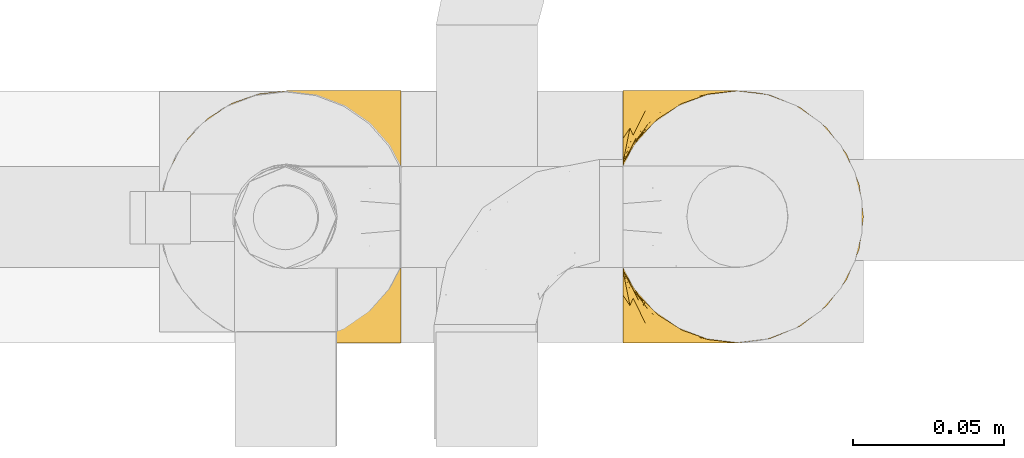
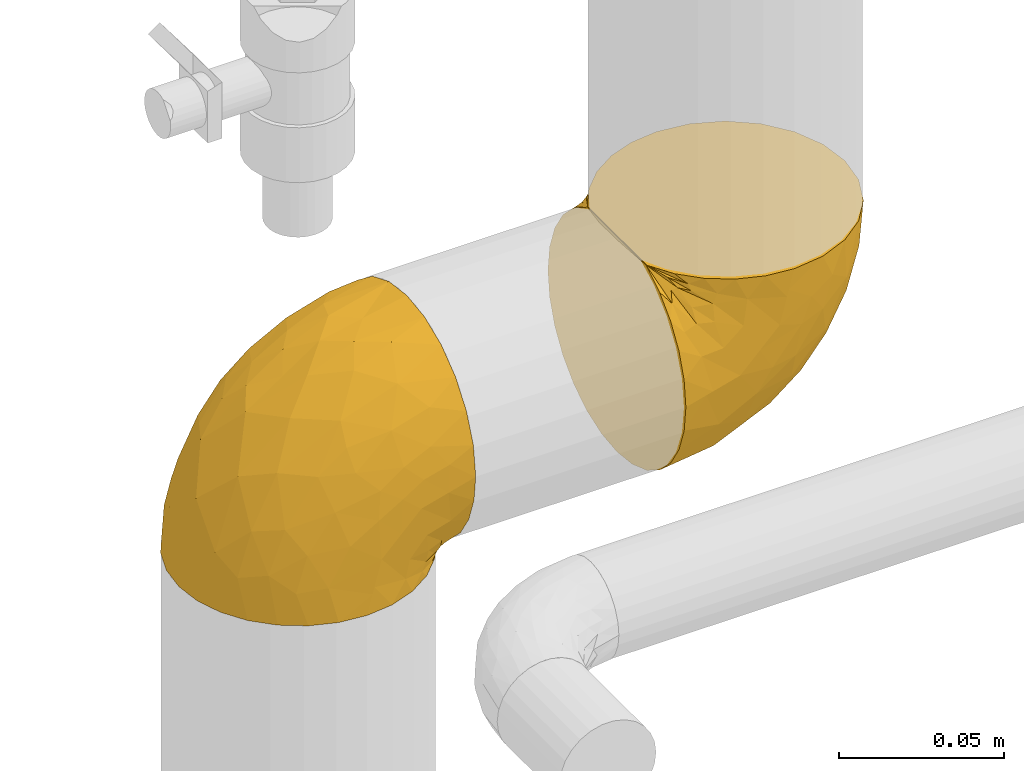
# One storey, part 358 of 827: 2 coverings.
"""IFC2X3 building model written with IfcOpenShell, lengths in millimetres."""

from ifc_helpers import new_model, entity, si_unit, converted_unit, derived_unit, direction, frame, origin, place, context, subcontext, project, spatial, faceted_brep, element, save


model = new_model("IFC2X3")

# Units and contexts
model_context = context("Model", 3, precision=0.01, world=origin(), true_north=direction((6.12303176911189e-17, 1.0)))
body_context = subcontext(model_context, "Body", "Model", "MODEL_VIEW")
ifc_project = project(units=[si_unit("LENGTHUNIT", "METRE", prefix="MILLI"), si_unit("AREAUNIT", "SQUARE_METRE"), si_unit("VOLUMEUNIT", "CUBIC_METRE"), converted_unit("PLANEANGLEUNIT", "DEGREE", entity("IfcRatioMeasure", 0.0174532925199433), si_unit("PLANEANGLEUNIT", "RADIAN"), dimensions=[0, 0, 0, 0, 0, 0, 0]), si_unit("MASSUNIT", "GRAM", prefix="KILO"), derived_unit("MASSDENSITYUNIT", [(si_unit("MASSUNIT", "GRAM", prefix="KILO"), 1), (si_unit("LENGTHUNIT", "METRE"), -3)]), derived_unit("MOMENTOFINERTIAUNIT", [(si_unit("LENGTHUNIT", "METRE"), 4)]), si_unit("TIMEUNIT", "SECOND"), si_unit("FREQUENCYUNIT", "HERTZ"), si_unit("THERMODYNAMICTEMPERATUREUNIT", "DEGREE_CELSIUS"), derived_unit("THERMALTRANSMITTANCEUNIT", [(si_unit("MASSUNIT", "GRAM", prefix="KILO"), 1), (si_unit("THERMODYNAMICTEMPERATUREUNIT", "KELVIN"), -1), (si_unit("TIMEUNIT", "SECOND"), -3)]), derived_unit("VOLUMETRICFLOWRATEUNIT", [(si_unit("LENGTHUNIT", "METRE"), 3), (si_unit("TIMEUNIT", "SECOND"), -1)]), derived_unit("MASSFLOWRATEUNIT", [(si_unit("MASSUNIT", "GRAM", prefix="KILO"), 1), (si_unit("TIMEUNIT", "SECOND"), -1)]), derived_unit("ROTATIONALFREQUENCYUNIT", [(si_unit("TIMEUNIT", "SECOND"), -1)]), si_unit("ELECTRICCURRENTUNIT", "AMPERE"), si_unit("ELECTRICVOLTAGEUNIT", "VOLT"), si_unit("POWERUNIT", "WATT"), si_unit("FORCEUNIT", "NEWTON", prefix="KILO"), si_unit("ILLUMINANCEUNIT", "LUX"), si_unit("LUMINOUSFLUXUNIT", "LUMEN"), si_unit("LUMINOUSINTENSITYUNIT", "CANDELA"), derived_unit("USERDEFINED", [(si_unit("MASSUNIT", "GRAM", prefix="KILO"), -1), (si_unit("LENGTHUNIT", "METRE"), -2), (si_unit("TIMEUNIT", "SECOND"), 3), (si_unit("LUMINOUSFLUXUNIT", "LUMEN"), 1)]), derived_unit("LINEARVELOCITYUNIT", [(si_unit("LENGTHUNIT", "METRE"), 1), (si_unit("TIMEUNIT", "SECOND"), -1)]), si_unit("PRESSUREUNIT", "PASCAL"), derived_unit("USERDEFINED", [(si_unit("LENGTHUNIT", "METRE"), -2), (si_unit("MASSUNIT", "GRAM", prefix="KILO"), 1), (si_unit("TIMEUNIT", "SECOND"), -2)]), derived_unit("LINEARFORCEUNIT", [(si_unit("MASSUNIT", "GRAM", prefix="KILO"), 1), (si_unit("LENGTHUNIT", "METRE"), 1), (si_unit("TIMEUNIT", "SECOND"), -2), (si_unit("LENGTHUNIT", "METRE"), -1)]), derived_unit("PLANARFORCEUNIT", [(si_unit("MASSUNIT", "GRAM", prefix="KILO"), 1), (si_unit("LENGTHUNIT", "METRE"), 1), (si_unit("TIMEUNIT", "SECOND"), -2), (si_unit("LENGTHUNIT", "METRE"), -2)])], contexts=[model_context])

# Site, building, storey
site_placement = place(None, origin())
site = spatial("IfcSite", under=ifc_project, at=site_placement, CompositionType="ELEMENT")
building_placement = place(site_placement, origin())
building = spatial("IfcBuilding", under=site, at=building_placement, CompositionType="ELEMENT")
storey_placement = place(building_placement, frame((0.0, 0.0, 28200.0)))
storey = spatial("IfcBuildingStorey", under=building, at=storey_placement, Name="08", CompositionType="ELEMENT", Elevation=28200.0)

# Coverings
covering_1_placement = place(storey_placement, frame((43263.49, 18027.79, 1216.43)))
element("IfcCovering", 1, at=covering_1_placement, inside=storey, Name=":ADSK_", ObjectType=":ADSK_", PredefinedType="INSULATION", context=body_context, shape_type="Brep", body=[
    faceted_brep([(1.6, 81.15, 25.28), (1.6, 76.16, 17.35), (1.6, 69.53, 10.72), (1.6, 61.6, 5.74), (1.6, 52.75, 2.64), (1.6, 43.45, 1.6), (1.6, 34.13, 2.65), (1.6, 25.28, 5.74), (1.6, 17.35, 10.73), (1.6, 10.72, 17.36), (1.6, 5.74, 25.29), (1.6, 2.64, 34.14), (1.6, 1.6, 43.45), (1.6, 2.66, 52.82), (1.6, 5.79, 61.71), (1.6, 10.83, 69.67), (1.6, 17.53, 76.31), (1.6, 25.53, 81.27), (1.6, 26.45, 81.27), (1.6, 27.37, 81.27), (1.6, 28.17, 81.27), (1.6, 29.49, 81.27), (1.6, 30.81, 81.27), (1.6, 32.13, 81.27), (1.6, 33.45, 81.27), (1.6, 34.78, 81.27), (1.6, 36.1, 81.27), (1.6, 37.42, 81.27), (1.6, 38.74, 81.27), (1.6, 40.06, 81.27), (1.6, 41.38, 81.27), (1.6, 42.7, 81.27), (1.6, 44.02, 81.27), (1.6, 45.34, 81.27), (1.6, 46.66, 81.27), (1.6, 47.58, 81.27), (1.6, 48.5, 81.27), (1.6, 49.41, 81.27), (1.6, 50.33, 81.27), (1.6, 51.25, 81.27), (1.6, 52.17, 81.27), (1.6, 53.09, 81.27), (1.6, 54.01, 81.27), (1.6, 54.93, 81.27), (1.6, 55.85, 81.27), (1.6, 56.76, 81.27), (1.6, 57.68, 81.27), (1.6, 58.6, 81.27), (1.6, 59.52, 81.27), (1.6, 60.44, 81.27), (1.6, 61.36, 81.27), (1.6, 69.37, 76.3), (1.6, 76.07, 69.66), (1.6, 81.11, 61.69), (1.6, 84.24, 52.8), (1.6, 85.3, 43.45), (1.6, 84.24, 34.13), (6.74, 17.52, 81.45), (13.37, 10.83, 81.45), (21.34, 5.79, 81.45), (30.23, 2.66, 81.45), (39.6, 1.6, 81.45), (50.43, 3.02, 81.45), (60.52, 7.2, 81.45), (69.19, 13.85, 81.45), (75.84, 22.52, 81.45), (80.02, 32.61, 81.45), (81.45, 43.45, 81.45), (80.02, 54.28, 81.45), (75.84, 64.37, 81.45), (69.19, 73.04, 81.45), (60.52, 79.69, 81.45), (50.43, 83.87, 81.45), (39.6, 85.3, 81.45), (30.23, 84.23, 81.45), (21.34, 81.1, 81.45), (13.37, 76.06, 81.45), (6.74, 69.37, 81.45), (1.77, 61.36, 81.45), (1.77, 60.44, 81.45), (1.77, 59.12, 81.45), (1.77, 58.0, 81.45), (1.77, 56.88, 81.45), (1.77, 55.76, 81.45), (1.77, 54.64, 81.45), (1.77, 53.52, 81.45), (1.77, 52.4, 81.45), (1.77, 51.28, 81.45), (1.77, 50.16, 81.45), (1.77, 49.04, 81.45), (1.77, 47.92, 81.45), (1.77, 46.8, 81.45), (1.77, 45.68, 81.45), (1.77, 44.56, 81.45), (1.77, 43.45, 81.45), (1.77, 42.12, 81.45), (1.77, 40.8, 81.45), (1.77, 39.48, 81.45), (1.77, 38.16, 81.45), (1.77, 36.84, 81.45), (1.77, 35.52, 81.45), (1.77, 34.2, 81.45), (1.77, 32.88, 81.45), (1.77, 31.96, 81.45), (1.77, 31.05, 81.45), (1.77, 30.13, 81.45), (1.77, 29.21, 81.45), (1.77, 28.29, 81.45), (1.77, 27.37, 81.45), (1.77, 26.45, 81.45), (1.77, 25.53, 81.45), (1.73, 54.08, 81.33), (1.72, 55.16, 81.32), (1.73, 36.18, 81.33), (1.72, 35.13, 81.32), (1.73, 44.01, 81.33), (1.73, 45.08, 81.32), (1.72, 61.36, 81.32), (1.72, 59.98, 81.32), (1.72, 46.18, 81.32), (1.72, 26.74, 81.32), (1.72, 47.36, 81.32), (1.73, 29.67, 81.32), (1.74, 28.72, 81.34), (1.72, 39.77, 81.32), (1.71, 52.96, 81.31), (1.73, 51.84, 81.33), (1.71, 40.8, 81.31), (1.72, 41.87, 81.32), (1.73, 42.94, 81.33), (1.72, 27.77, 81.32), (1.73, 48.4, 81.33), (1.72, 37.21, 81.32), (1.73, 33.54, 81.33), (1.72, 32.49, 81.32), (1.72, 30.69, 81.32), (1.72, 50.69, 81.32), (1.71, 49.6, 81.31), (1.72, 56.32, 81.32), (1.73, 57.44, 81.33), (1.71, 58.88, 81.31), (1.72, 25.53, 81.32), (1.68, 61.36, 81.3), (1.64, 61.36, 81.29), (1.64, 25.53, 81.29), (1.68, 25.53, 81.3), (1.75, 61.36, 81.4), (1.74, 61.36, 81.36), (1.74, 25.53, 81.36), (1.75, 25.53, 81.4), (1.7, 31.59, 81.3), (1.73, 38.71, 81.33), (24.54, 3.97, 74.06), (11.1, 1.6, 45.99), (8.47, 3.97, 58.35), (9.11, 8.09, 67.76), (4.86, 8.09, 66.18), (5.0, 16.43, 76.46), (6.81, 15.73, 77.33), (37.05, 1.6, 71.95), (9.03, 10.79, 72.25), (9.47, 13.99, 78.91), (16.39, 8.08, 76.42), (3.95, 14.0, 73.52), (9.9, 12.83, 76.9), (22.7, 3.18, 65.25), (34.5, 1.6, 62.45), (37.68, 1.6, 74.31), (15.82, 3.28, 59.38), (20.6, 1.6, 48.54), (14.37, 6.28, 67.72), (27.55, 1.6, 55.49), (5.2, 19.06, 79.73), (14.88, 8.08, 73.23), (8.73, 1.6, 45.36), (44.27, 32.11, 15.81), (20.94, 29.62, 6.4), (32.15, 43.45, 7.67), (46.13, 2.45, 68.46), (42.67, 2.5, 59.33), (55.18, 9.73, 48.7), (67.27, 17.97, 53.94), (62.91, 10.24, 65.02), (51.5, 4.78, 60.77), (54.79, 4.78, 72.07), (25.78, 8.01, 26.25), (13.05, 8.01, 22.29), (18.46, 13.85, 16.0), (32.4, 2.42, 46.93), (31.07, 21.17, 14.19), (77.32, 35.73, 58.46), (75.62, 27.43, 61.51), (16.9, 43.45, 4.64), (71.69, 17.97, 68.93), (61.4, 35.71, 29.62), (54.47, 29.47, 24.85), (27.66, 3.41, 38.55), (14.53, 3.94, 31.27), (15.56, 21.17, 9.35), (42.26, 7.92, 37.15), (41.51, 4.25, 47.07), (36.93, 11.75, 26.49), (42.72, 18.31, 23.01), (44.68, 24.94, 19.4), (71.2, 28.78, 48.06), (70.48, 35.82, 42.46), (75.37, 43.45, 50.89), (63.65, 28.38, 35.78), (58.06, 43.45, 24.98), (45.11, 43.45, 16.33), (78.4, 43.45, 66.14), (54.95, 21.21, 30.96), (59.31, 16.48, 41.83), (49.01, 13.85, 33.28), (66.71, 43.45, 37.94), (53.75, 82.11, 67.39), (77.27, 51.41, 58.47), (61.6, 57.45, 32.5), (44.24, 54.78, 15.79), (18.46, 73.03, 15.99), (15.55, 65.7, 9.34), (60.14, 76.65, 56.91), (70.5, 68.92, 63.5), (63.0, 68.01, 44.08), (25.78, 78.88, 26.24), (13.05, 78.88, 22.27), (14.53, 82.94, 31.26), (48.5, 64.44, 23.95), (44.23, 84.49, 63.79), (34.5, 85.3, 62.45), (37.05, 85.3, 71.95), (8.73, 85.3, 45.36), (77.68, 57.84, 67.83), (64.08, 76.65, 70.28), (70.25, 51.19, 42.11), (20.93, 57.26, 6.39), (49.9, 78.14, 43.54), (49.6, 82.35, 58.03), (31.06, 65.7, 14.18), (39.62, 84.61, 56.34), (34.42, 84.36, 48.09), (20.6, 85.3, 48.54), (27.55, 85.3, 55.49), (33.36, 73.03, 21.78), (27.68, 83.48, 38.54), (11.1, 85.3, 45.99), (46.67, 84.54, 72.79), (49.0, 73.03, 33.26), (38.94, 79.54, 35.53), (73.05, 59.46, 53.66), (56.63, 73.5, 43.03), (43.85, 82.57, 49.68), (24.54, 82.92, 74.06), (15.82, 83.62, 59.37), (8.47, 82.92, 58.34), (9.12, 78.81, 67.75), (9.47, 72.9, 78.91), (9.91, 74.06, 76.9), (16.85, 78.81, 78.08), (14.88, 78.81, 73.23), (5.2, 67.83, 79.73), (6.81, 71.15, 77.34), (3.96, 72.91, 73.51), (5.0, 70.47, 76.45), (5.86, 78.81, 66.41), (14.38, 80.62, 67.7), (9.04, 76.11, 72.24), (22.7, 83.71, 65.25)], [[[0, 1, 2, 3, 4, 5, 6, 7, 8, 9, 10, 11, 12, 13, 14, 15, 16, 17, 18, 19, 20, 21, 22, 23, 24, 25, 26, 27, 28, 29, 30, 31, 32, 33, 34, 35, 36, 37, 38, 39, 40, 41, 42, 43, 44, 45, 46, 47, 48, 49, 50, 51, 52, 53, 54, 55, 56]], [[57, 58, 59, 60, 61, 62, 63, 64, 65, 66, 67, 68, 69, 70, 71, 72, 73, 74, 75, 76, 77, 78, 79, 80, 81, 82, 83, 84, 85, 86, 87, 88, 89, 90, 91, 92, 93, 94, 95, 96, 97, 98, 99, 100, 101, 102, 103, 104, 105, 106, 107, 108, 109, 110]], [[111, 84, 112]], [[113, 26, 114]], [[114, 101, 100]], [[115, 93, 116]], [[79, 117, 118]], [[33, 116, 119]], [[117, 49, 118]], [[19, 18, 120]], [[119, 121, 34]], [[122, 21, 123]], [[97, 96, 124]], [[86, 125, 126]], [[116, 92, 119]], [[127, 96, 128]], [[32, 129, 115]], [[19, 120, 130]], [[121, 90, 131]], [[94, 115, 129]], [[115, 116, 32]], [[118, 49, 48]], [[113, 99, 132]], [[133, 114, 25]], [[24, 134, 133]], [[135, 22, 122]], [[136, 137, 88]], [[84, 83, 112]], [[138, 82, 139]], [[130, 20, 19]], [[118, 48, 140]], [[81, 140, 139]], [[123, 21, 20]], [[141, 120, 18]], [[139, 82, 81]], [[130, 107, 123]], [[49, 117, 142, 143, 50]], [[18, 17, 144, 145, 141]], [[79, 78, 146, 147, 117]], [[109, 141, 148, 149, 110]], [[102, 133, 134]], [[105, 135, 122]], [[118, 80, 79]], [[80, 118, 140]], [[120, 109, 108]], [[47, 46, 140, 48]], [[81, 80, 140]], [[44, 112, 138]], [[93, 115, 94]], [[46, 139, 140]], [[46, 45, 139]], [[139, 45, 138]], [[138, 112, 83]], [[85, 84, 111]], [[112, 43, 111]], [[83, 82, 138]], [[106, 122, 123]], [[105, 122, 106]], [[21, 122, 22]], [[124, 29, 28]], [[33, 32, 116]], [[128, 129, 31]], [[32, 31, 129]], [[34, 33, 119]], [[116, 93, 92]], [[129, 95, 94]], [[95, 129, 128]], [[41, 40, 125, 42]], [[119, 91, 121]], [[36, 35, 131, 37]], [[137, 131, 89]], [[121, 131, 35]], [[90, 121, 91]], [[119, 92, 91]], [[136, 126, 39]], [[125, 86, 85]], [[42, 125, 111]], [[85, 111, 125]], [[150, 23, 22]], [[130, 108, 107]], [[130, 123, 20]], [[107, 106, 123]], [[137, 37, 131]], [[136, 38, 137]], [[89, 88, 137]], [[131, 90, 89]], [[124, 151, 97]], [[40, 39, 126]], [[87, 126, 136]], [[86, 126, 87]], [[136, 88, 87]], [[40, 126, 125]], [[39, 38, 136]], [[95, 128, 96]], [[30, 128, 31]], [[29, 124, 127]], [[127, 128, 30]], [[151, 124, 28]], [[127, 30, 29]], [[127, 124, 96]], [[151, 98, 97]], [[45, 44, 138]], [[26, 113, 132]], [[113, 100, 99]], [[132, 151, 27]], [[27, 26, 132]], [[26, 25, 114]], [[100, 113, 114]], [[101, 133, 102]], [[133, 101, 114]], [[28, 27, 151]], [[132, 99, 98]], [[23, 134, 24]], [[25, 24, 133]], [[134, 23, 150]], [[135, 104, 150]], [[150, 104, 103]], [[103, 102, 134]], [[130, 120, 108]], [[109, 120, 141]], [[42, 111, 43]], [[112, 44, 43]], [[104, 135, 105]], [[134, 150, 103]], [[135, 150, 22]], [[35, 34, 121]], [[137, 38, 37]], [[98, 151, 132]], [[59, 152, 60]], [[13, 153, 154]], [[155, 156, 154]], [[157, 158, 141]], [[159, 60, 152]], [[160, 157, 155]], [[161, 162, 58]], [[58, 162, 59]], [[144, 16, 163]], [[58, 57, 161]], [[162, 161, 164]], [[157, 163, 155]], [[163, 16, 15]], [[57, 149, 161]], [[152, 165, 166]], [[157, 144, 163]], [[60, 159, 167, 61]], [[156, 14, 154]], [[163, 156, 155]], [[155, 154, 168]], [[168, 154, 169]], [[155, 170, 160]], [[57, 110, 149]], [[144, 17, 16]], [[156, 15, 14]], [[171, 165, 168]], [[158, 164, 172]], [[14, 13, 154]], [[157, 145, 144]], [[173, 164, 158]], [[173, 160, 170]], [[171, 166, 165]], [[168, 165, 170]], [[168, 169, 171]], [[152, 173, 165]], [[170, 155, 168]], [[165, 173, 170]], [[160, 173, 158]], [[172, 149, 148]], [[148, 141, 158]], [[158, 157, 160]], [[152, 166, 159]], [[173, 152, 162]], [[59, 162, 152]], [[13, 12, 174, 153]], [[153, 169, 154]], [[15, 156, 163]], [[157, 141, 145]], [[162, 164, 173]], [[172, 164, 161]], [[149, 172, 161]], [[158, 172, 148]], [[175, 176, 177]], [[178, 166, 179]], [[180, 181, 182]], [[183, 184, 178]], [[185, 186, 187]], [[171, 188, 179]], [[174, 12, 11]], [[189, 176, 175]], [[190, 66, 191]], [[176, 6, 192]], [[193, 65, 64]], [[63, 184, 182]], [[63, 182, 64]], [[65, 193, 191]], [[184, 63, 62]], [[175, 194, 195]], [[196, 169, 197]], [[174, 11, 197]], [[8, 7, 198]], [[187, 9, 8]], [[197, 169, 153, 174]], [[197, 11, 10]], [[186, 197, 10]], [[199, 180, 200]], [[197, 185, 196]], [[201, 189, 202]], [[201, 187, 189]], [[195, 203, 175]], [[191, 204, 190]], [[176, 7, 6]], [[177, 176, 192]], [[189, 198, 176]], [[65, 191, 66]], [[198, 187, 8]], [[205, 206, 190]], [[9, 186, 10]], [[181, 207, 204]], [[208, 175, 177, 209]], [[66, 190, 210]], [[211, 212, 213]], [[190, 204, 205]], [[180, 182, 183]], [[193, 182, 181]], [[62, 61, 167]], [[196, 185, 199]], [[196, 200, 188]], [[6, 5, 192]], [[176, 198, 7]], [[187, 198, 189]], [[187, 186, 9]], [[197, 186, 185]], [[200, 180, 183]], [[180, 213, 212]], [[179, 183, 178]], [[185, 201, 199]], [[210, 190, 206]], [[210, 67, 66]], [[205, 204, 207]], [[194, 205, 207]], [[194, 214, 205]], [[195, 194, 207]], [[208, 194, 175]], [[207, 211, 195]], [[202, 203, 211]], [[212, 207, 181]], [[202, 211, 213]], [[201, 202, 213]], [[189, 175, 203]], [[199, 201, 213]], [[187, 201, 185]], [[180, 199, 213]], [[196, 199, 200]], [[211, 203, 195]], [[189, 203, 202]], [[207, 212, 211]], [[180, 212, 181]], [[214, 194, 208]], [[214, 206, 205]], [[196, 188, 169]], [[181, 204, 191]], [[182, 193, 64]], [[191, 193, 181]], [[178, 62, 167]], [[182, 184, 183]], [[62, 178, 184]], [[178, 167, 159, 166]], [[171, 179, 166]], [[200, 183, 179]], [[179, 188, 200]], [[169, 188, 171]], [[71, 215, 72]], [[206, 216, 210]], [[217, 208, 218]], [[216, 68, 210]], [[219, 220, 2]], [[221, 222, 223]], [[224, 225, 226]], [[227, 223, 217]], [[228, 229, 230]], [[56, 231, 226]], [[232, 222, 69]], [[56, 55, 231]], [[70, 233, 71]], [[71, 233, 215]], [[0, 56, 226]], [[208, 217, 234]], [[218, 177, 235]], [[221, 236, 237]], [[238, 220, 219]], [[1, 219, 2]], [[68, 216, 232]], [[235, 3, 220]], [[235, 192, 4]], [[1, 0, 225]], [[228, 239, 229]], [[240, 241, 242]], [[243, 238, 219]], [[224, 226, 244]], [[226, 241, 244]], [[3, 235, 4]], [[69, 222, 70]], [[225, 219, 1]], [[218, 235, 238]], [[243, 219, 224]], [[218, 227, 217]], [[3, 2, 220]], [[218, 208, 209, 177]], [[226, 231, 245, 241]], [[215, 228, 246]], [[247, 248, 236]], [[248, 224, 244]], [[223, 222, 249]], [[233, 222, 221]], [[242, 239, 240]], [[248, 247, 243]], [[217, 223, 249]], [[250, 247, 236]], [[216, 234, 249]], [[218, 238, 227]], [[192, 235, 177]], [[192, 5, 4]], [[72, 246, 73]], [[235, 220, 238]], [[226, 225, 0]], [[219, 225, 224]], [[240, 248, 244]], [[239, 242, 229]], [[236, 248, 251]], [[68, 67, 210]], [[234, 216, 206]], [[216, 249, 232]], [[234, 206, 214, 208]], [[249, 234, 217]], [[222, 232, 249]], [[69, 68, 232]], [[246, 228, 230]], [[237, 228, 215]], [[243, 227, 238]], [[223, 227, 247]], [[73, 246, 230]], [[215, 246, 72]], [[248, 243, 224]], [[227, 243, 247]], [[237, 236, 251]], [[250, 221, 223]], [[222, 233, 70]], [[215, 233, 221]], [[221, 237, 215]], [[239, 237, 251]], [[237, 239, 228]], [[239, 251, 240]], [[248, 240, 251]], [[241, 240, 244]], [[221, 250, 236]], [[223, 247, 250]], [[74, 230, 252]], [[253, 254, 255]], [[146, 77, 256]], [[257, 258, 259]], [[260, 256, 257]], [[260, 261, 147]], [[75, 74, 252]], [[51, 143, 262]], [[263, 143, 142, 117]], [[256, 77, 76]], [[252, 258, 75]], [[253, 241, 254]], [[254, 245, 54]], [[258, 256, 76]], [[53, 52, 264]], [[255, 265, 253]], [[254, 264, 255]], [[255, 264, 262]], [[75, 258, 76]], [[265, 255, 266]], [[255, 262, 263]], [[51, 50, 143]], [[54, 245, 231, 55]], [[51, 262, 52]], [[253, 267, 242]], [[254, 54, 53]], [[266, 259, 265]], [[146, 78, 77]], [[263, 117, 261]], [[146, 256, 260]], [[257, 259, 261]], [[267, 253, 265]], [[229, 267, 252]], [[242, 267, 229]], [[242, 241, 253]], [[252, 267, 259]], [[255, 263, 266]], [[259, 267, 265]], [[261, 117, 147]], [[263, 261, 266]], [[259, 266, 261]], [[230, 74, 73]], [[230, 229, 252]], [[259, 258, 252]], [[254, 241, 245]], [[53, 264, 254]], [[52, 262, 264]], [[143, 263, 262]], [[258, 257, 256]], [[261, 260, 257]], [[146, 260, 147]]]),
])
covering_2_placement = place(storey_placement, frame((43110.06, 18027.79, 1220.28)))
element("IfcCovering", 2, at=covering_2_placement, inside=storey, Name=":ADSK_", ObjectType=":ADSK_", PredefinedType="INSULATION", context=body_context, shape_type="Brep", body=[
    faceted_brep([(25.28, 5.74, 1.6), (17.35, 10.73, 1.6), (10.72, 17.36, 1.6), (5.74, 25.29, 1.6), (2.64, 34.14, 1.6), (1.6, 43.45, 1.6), (2.65, 52.76, 1.6), (5.74, 61.61, 1.6), (10.73, 69.54, 1.6), (17.36, 76.17, 1.6), (25.29, 81.15, 1.6), (34.14, 84.25, 1.6), (43.45, 85.3, 1.6), (52.82, 84.23, 1.6), (61.71, 81.1, 1.6), (69.67, 76.06, 1.6), (76.31, 69.36, 1.6), (81.27, 61.36, 1.6), (81.27, 60.44, 1.6), (81.27, 59.52, 1.6), (81.27, 58.72, 1.6), (81.27, 57.4, 1.6), (81.27, 56.08, 1.6), (81.27, 54.76, 1.6), (81.27, 53.44, 1.6), (81.27, 52.12, 1.6), (81.27, 50.8, 1.6), (81.27, 49.47, 1.6), (81.27, 48.15, 1.6), (81.27, 46.83, 1.6), (81.27, 45.51, 1.6), (81.27, 44.19, 1.6), (81.27, 42.87, 1.6), (81.27, 41.55, 1.6), (81.27, 40.23, 1.6), (81.27, 39.31, 1.6), (81.27, 38.39, 1.6), (81.27, 37.48, 1.6), (81.27, 36.56, 1.6), (81.27, 35.64, 1.6), (81.27, 34.72, 1.6), (81.27, 33.8, 1.6), (81.27, 32.88, 1.6), (81.27, 31.96, 1.6), (81.27, 31.05, 1.6), (81.27, 30.13, 1.6), (81.27, 29.21, 1.6), (81.27, 28.29, 1.6), (81.27, 27.37, 1.6), (81.27, 26.45, 1.6), (81.27, 25.53, 1.6), (76.3, 17.52, 1.6), (69.66, 10.82, 1.6), (61.69, 5.78, 1.6), (52.8, 2.65, 1.6), (43.45, 1.6, 1.6), (34.13, 2.65, 1.6), (81.45, 69.37, 6.74), (81.45, 76.06, 13.37), (81.45, 81.1, 21.34), (81.45, 84.23, 30.23), (81.45, 85.3, 39.6), (81.45, 83.87, 50.43), (81.45, 79.69, 60.52), (81.45, 73.04, 69.19), (81.45, 64.37, 75.84), (81.45, 54.28, 80.02), (81.45, 43.45, 81.45), (81.45, 32.61, 80.02), (81.45, 22.52, 75.84), (81.45, 13.85, 69.19), (81.45, 7.2, 60.52), (81.45, 3.02, 50.43), (81.45, 1.6, 39.6), (81.45, 2.66, 30.23), (81.45, 5.79, 21.34), (81.45, 10.83, 13.37), (81.45, 17.52, 6.74), (81.45, 25.53, 1.77), (81.45, 26.45, 1.77), (81.45, 27.77, 1.77), (81.45, 28.89, 1.77), (81.45, 30.01, 1.77), (81.45, 31.13, 1.77), (81.45, 32.25, 1.77), (81.45, 33.37, 1.77), (81.45, 34.49, 1.77), (81.45, 35.61, 1.77), (81.45, 36.73, 1.77), (81.45, 37.85, 1.77), (81.45, 38.97, 1.77), (81.45, 40.09, 1.77), (81.45, 41.21, 1.77), (81.45, 42.33, 1.77), (81.45, 43.45, 1.77), (81.45, 44.77, 1.77), (81.45, 46.09, 1.77), (81.45, 47.41, 1.77), (81.45, 48.73, 1.77), (81.45, 50.05, 1.77), (81.45, 51.37, 1.77), (81.45, 52.69, 1.77), (81.45, 54.01, 1.77), (81.45, 54.93, 1.77), (81.45, 55.85, 1.77), (81.45, 56.76, 1.77), (81.45, 57.68, 1.77), (81.45, 58.6, 1.77), (81.45, 59.52, 1.77), (81.45, 60.44, 1.77), (81.45, 61.36, 1.77), (81.33, 32.81, 1.73), (81.32, 31.73, 1.72), (81.33, 50.71, 1.73), (81.32, 51.76, 1.72), (81.33, 42.89, 1.73), (81.32, 41.81, 1.73), (81.32, 25.53, 1.72), (81.32, 26.91, 1.72), (81.32, 40.71, 1.72), (81.32, 60.15, 1.72), (81.32, 39.53, 1.72), (81.32, 57.22, 1.73), (81.34, 58.17, 1.74), (81.32, 47.12, 1.72), (81.31, 33.93, 1.71), (81.33, 35.05, 1.73), (81.31, 46.09, 1.71), (81.32, 45.02, 1.72), (81.33, 43.95, 1.73), (81.32, 59.12, 1.72), (81.33, 38.49, 1.73), (81.32, 49.68, 1.72), (81.33, 53.35, 1.73), (81.32, 54.4, 1.72), (81.32, 56.2, 1.72), (81.32, 36.2, 1.72), (81.31, 37.29, 1.71), (81.32, 30.57, 1.72), (81.33, 29.45, 1.73), (81.31, 28.01, 1.71), (81.32, 61.36, 1.72), (81.3, 25.53, 1.68), (81.29, 25.53, 1.64), (81.29, 61.36, 1.64), (81.3, 61.36, 1.68), (81.4, 25.53, 1.75), (81.36, 25.53, 1.74), (81.36, 61.36, 1.74), (81.4, 61.36, 1.75), (81.3, 55.3, 1.7), (81.33, 48.18, 1.73), (74.06, 82.92, 24.54), (45.99, 85.3, 11.1), (58.35, 82.92, 8.47), (67.76, 78.8, 9.11), (66.18, 78.8, 4.86), (76.46, 70.46, 5.0), (77.33, 71.16, 6.81), (71.95, 85.3, 37.05), (72.25, 76.1, 9.03), (78.91, 72.9, 9.47), (76.42, 78.81, 16.39), (73.52, 72.89, 3.95), (76.9, 74.06, 9.9), (65.25, 83.71, 22.7), (62.45, 85.3, 34.5), (74.31, 85.3, 37.68), (59.38, 83.61, 15.82), (48.54, 85.3, 20.6), (67.72, 80.61, 14.37), (55.49, 85.3, 27.55), (79.73, 67.83, 5.2), (73.23, 78.81, 14.88), (45.36, 85.3, 8.73), (15.81, 54.78, 44.27), (6.4, 57.27, 20.94), (7.67, 43.45, 32.15), (68.46, 84.45, 46.13), (59.33, 84.39, 42.67), (48.7, 77.16, 55.18), (53.94, 68.92, 67.27), (65.02, 76.65, 62.91), (60.77, 82.11, 51.5), (72.07, 82.11, 54.79), (26.25, 78.88, 25.78), (22.29, 78.88, 13.05), (16.0, 73.04, 18.46), (46.93, 84.47, 32.4), (14.19, 65.72, 31.07), (58.46, 51.16, 77.32), (61.51, 59.46, 75.62), (4.64, 43.45, 16.9), (68.93, 68.92, 71.69), (29.62, 51.18, 61.4), (24.85, 57.42, 54.47), (38.55, 83.48, 27.66), (31.27, 82.95, 14.53), (9.35, 65.72, 15.56), (37.15, 78.97, 42.26), (47.07, 82.64, 41.51), (26.49, 75.14, 36.93), (23.01, 68.58, 42.72), (19.4, 61.95, 44.68), (48.06, 58.11, 71.2), (42.46, 51.07, 70.48), (50.89, 43.45, 75.37), (35.78, 58.51, 63.65), (24.98, 43.45, 58.06), (16.33, 43.45, 45.11), (66.14, 43.45, 78.4), (30.96, 65.68, 54.95), (41.83, 70.41, 59.31), (33.28, 73.04, 49.01), (37.94, 43.45, 66.71), (67.39, 4.78, 53.75), (58.47, 35.48, 77.27), (32.5, 29.45, 61.6), (15.79, 32.11, 44.24), (15.99, 13.86, 18.46), (9.34, 21.19, 15.55), (56.91, 10.24, 60.14), (63.5, 17.97, 70.5), (44.08, 18.88, 63.0), (26.24, 8.01, 25.78), (22.27, 8.01, 13.05), (31.26, 3.95, 14.53), (23.95, 22.45, 48.5), (63.79, 2.4, 44.23), (62.45, 1.6, 34.5), (71.95, 1.6, 37.05), (45.36, 1.6, 8.73), (67.83, 29.05, 77.68), (70.28, 10.24, 64.08), (42.11, 35.7, 70.25), (6.39, 29.63, 20.93), (43.54, 8.75, 49.9), (58.03, 4.54, 49.6), (14.18, 21.19, 31.06), (56.34, 2.28, 39.62), (48.09, 2.53, 34.42), (48.54, 1.6, 20.6), (55.49, 1.6, 27.55), (21.78, 13.86, 33.36), (38.54, 3.41, 27.68), (45.99, 1.6, 11.1), (72.79, 2.35, 46.67), (33.26, 13.86, 49.0), (35.53, 7.35, 38.94), (53.66, 27.43, 73.05), (43.03, 13.39, 56.63), (49.68, 4.32, 43.85), (74.06, 3.97, 24.54), (59.37, 3.27, 15.82), (58.34, 3.97, 8.47), (67.75, 8.08, 9.12), (78.91, 13.99, 9.47), (76.9, 12.83, 9.91), (78.08, 8.08, 16.85), (73.23, 8.08, 14.88), (79.73, 19.06, 5.2), (77.34, 15.74, 6.81), (73.51, 13.98, 3.96), (76.45, 16.42, 5.0), (66.41, 8.08, 5.86), (67.7, 6.27, 14.38), (72.24, 10.78, 9.04), (65.25, 3.18, 22.7)], [[[0, 1, 2, 3, 4, 5, 6, 7, 8, 9, 10, 11, 12, 13, 14, 15, 16, 17, 18, 19, 20, 21, 22, 23, 24, 25, 26, 27, 28, 29, 30, 31, 32, 33, 34, 35, 36, 37, 38, 39, 40, 41, 42, 43, 44, 45, 46, 47, 48, 49, 50, 51, 52, 53, 54, 55, 56]], [[57, 58, 59, 60, 61, 62, 63, 64, 65, 66, 67, 68, 69, 70, 71, 72, 73, 74, 75, 76, 77, 78, 79, 80, 81, 82, 83, 84, 85, 86, 87, 88, 89, 90, 91, 92, 93, 94, 95, 96, 97, 98, 99, 100, 101, 102, 103, 104, 105, 106, 107, 108, 109, 110]], [[111, 84, 112]], [[113, 26, 114]], [[114, 101, 100]], [[115, 93, 116]], [[79, 117, 118]], [[33, 116, 119]], [[117, 49, 118]], [[19, 18, 120]], [[119, 121, 34]], [[122, 21, 123]], [[97, 96, 124]], [[86, 125, 126]], [[116, 92, 119]], [[127, 96, 128]], [[32, 129, 115]], [[19, 120, 130]], [[121, 90, 131]], [[94, 115, 129]], [[115, 116, 32]], [[118, 49, 48]], [[113, 99, 132]], [[133, 114, 25]], [[24, 134, 133]], [[135, 22, 122]], [[136, 137, 88]], [[84, 83, 112]], [[138, 82, 139]], [[130, 20, 19]], [[118, 48, 140]], [[81, 140, 139]], [[123, 21, 20]], [[141, 120, 18]], [[139, 82, 81]], [[130, 107, 123]], [[49, 117, 142, 143, 50]], [[18, 17, 144, 145, 141]], [[79, 78, 146, 147, 117]], [[109, 141, 148, 149, 110]], [[102, 133, 134]], [[105, 135, 122]], [[118, 80, 79]], [[80, 118, 140]], [[120, 109, 108]], [[47, 46, 140, 48]], [[81, 80, 140]], [[44, 112, 138]], [[93, 115, 94]], [[46, 139, 140]], [[46, 45, 139]], [[139, 45, 138]], [[138, 112, 83]], [[85, 84, 111]], [[112, 43, 111]], [[83, 82, 138]], [[106, 122, 123]], [[105, 122, 106]], [[21, 122, 22]], [[124, 29, 28]], [[33, 32, 116]], [[128, 129, 31]], [[32, 31, 129]], [[34, 33, 119]], [[116, 93, 92]], [[129, 95, 94]], [[95, 129, 128]], [[41, 40, 125, 42]], [[119, 91, 121]], [[36, 35, 131, 37]], [[137, 131, 89]], [[121, 131, 35]], [[90, 121, 91]], [[119, 92, 91]], [[136, 126, 39]], [[125, 86, 85]], [[42, 125, 111]], [[85, 111, 125]], [[150, 23, 22]], [[130, 108, 107]], [[130, 123, 20]], [[107, 106, 123]], [[137, 37, 131]], [[136, 38, 137]], [[89, 88, 137]], [[131, 90, 89]], [[124, 151, 97]], [[40, 39, 126]], [[87, 126, 136]], [[86, 126, 87]], [[136, 88, 87]], [[40, 126, 125]], [[39, 38, 136]], [[95, 128, 96]], [[30, 128, 31]], [[29, 124, 127]], [[127, 128, 30]], [[151, 124, 28]], [[127, 30, 29]], [[127, 124, 96]], [[151, 98, 97]], [[45, 44, 138]], [[26, 113, 132]], [[113, 100, 99]], [[132, 151, 27]], [[27, 26, 132]], [[26, 25, 114]], [[100, 113, 114]], [[101, 133, 102]], [[133, 101, 114]], [[28, 27, 151]], [[132, 99, 98]], [[23, 134, 24]], [[25, 24, 133]], [[134, 23, 150]], [[135, 104, 150]], [[150, 104, 103]], [[103, 102, 134]], [[130, 120, 108]], [[109, 120, 141]], [[42, 111, 43]], [[112, 44, 43]], [[104, 135, 105]], [[134, 150, 103]], [[135, 150, 22]], [[35, 34, 121]], [[137, 38, 37]], [[98, 151, 132]], [[59, 152, 60]], [[13, 153, 154]], [[155, 156, 154]], [[157, 158, 141]], [[159, 60, 152]], [[160, 157, 155]], [[161, 162, 58]], [[58, 162, 59]], [[144, 16, 163]], [[58, 57, 161]], [[162, 161, 164]], [[157, 163, 155]], [[163, 16, 15]], [[57, 149, 161]], [[152, 165, 166]], [[157, 144, 163]], [[60, 159, 167, 61]], [[156, 14, 154]], [[163, 156, 155]], [[155, 154, 168]], [[168, 154, 169]], [[155, 170, 160]], [[57, 110, 149]], [[144, 17, 16]], [[156, 15, 14]], [[171, 165, 168]], [[158, 164, 172]], [[14, 13, 154]], [[157, 141, 145, 144]], [[173, 164, 158]], [[173, 160, 170]], [[171, 166, 165]], [[168, 165, 170]], [[168, 169, 171]], [[152, 173, 165]], [[170, 155, 168]], [[165, 173, 170]], [[160, 173, 158]], [[172, 149, 148]], [[148, 141, 158]], [[158, 157, 160]], [[152, 166, 159]], [[173, 152, 162]], [[59, 162, 152]], [[13, 12, 174, 153]], [[153, 169, 154]], [[15, 156, 163]], [[162, 164, 173]], [[172, 164, 161]], [[149, 172, 161]], [[158, 172, 148]], [[175, 176, 177]], [[178, 166, 179]], [[180, 181, 182]], [[183, 184, 178]], [[185, 186, 187]], [[171, 188, 179]], [[174, 12, 11]], [[189, 176, 175]], [[190, 66, 191]], [[176, 6, 192]], [[193, 65, 64]], [[63, 184, 182]], [[63, 182, 64]], [[65, 193, 191]], [[184, 63, 62]], [[175, 194, 195]], [[196, 169, 197]], [[174, 11, 197]], [[8, 7, 198]], [[187, 9, 8]], [[197, 169, 153, 174]], [[197, 11, 10]], [[186, 197, 10]], [[199, 180, 200]], [[197, 185, 196]], [[201, 189, 202]], [[201, 187, 189]], [[195, 203, 175]], [[191, 204, 190]], [[176, 7, 6]], [[177, 176, 192]], [[189, 198, 176]], [[65, 191, 66]], [[198, 187, 8]], [[205, 206, 190]], [[9, 186, 10]], [[181, 207, 204]], [[208, 175, 177, 209]], [[66, 190, 210]], [[211, 212, 213]], [[190, 204, 205]], [[180, 182, 183]], [[193, 182, 181]], [[62, 61, 167]], [[196, 185, 199]], [[196, 200, 188]], [[6, 5, 192]], [[176, 198, 7]], [[187, 198, 189]], [[187, 186, 9]], [[197, 186, 185]], [[200, 180, 183]], [[180, 213, 212]], [[179, 183, 178]], [[185, 201, 199]], [[210, 190, 206]], [[210, 67, 66]], [[205, 204, 207]], [[194, 205, 207]], [[194, 214, 205]], [[195, 194, 207]], [[208, 194, 175]], [[207, 211, 195]], [[202, 203, 211]], [[212, 207, 181]], [[202, 211, 213]], [[201, 202, 213]], [[189, 175, 203]], [[199, 201, 213]], [[187, 201, 185]], [[180, 199, 213]], [[196, 199, 200]], [[211, 203, 195]], [[189, 203, 202]], [[207, 212, 211]], [[180, 212, 181]], [[214, 194, 208]], [[214, 206, 205]], [[196, 188, 169]], [[181, 204, 191]], [[182, 193, 64]], [[191, 193, 181]], [[178, 62, 167]], [[182, 184, 183]], [[62, 178, 184]], [[178, 167, 159, 166]], [[171, 179, 166]], [[200, 183, 179]], [[179, 188, 200]], [[169, 188, 171]], [[71, 215, 72]], [[206, 216, 210]], [[217, 208, 218]], [[216, 68, 210]], [[219, 220, 2]], [[221, 222, 223]], [[224, 225, 226]], [[227, 223, 217]], [[228, 229, 230]], [[56, 231, 226]], [[232, 222, 69]], [[56, 55, 231]], [[70, 233, 71]], [[71, 233, 215]], [[0, 56, 226]], [[208, 217, 234]], [[218, 177, 235]], [[221, 236, 237]], [[238, 220, 219]], [[1, 219, 2]], [[68, 216, 232]], [[235, 3, 220]], [[235, 192, 4]], [[1, 0, 225]], [[228, 239, 229]], [[240, 241, 242]], [[243, 238, 219]], [[224, 226, 244]], [[226, 241, 244]], [[3, 235, 4]], [[69, 222, 70]], [[225, 219, 1]], [[218, 235, 238]], [[243, 219, 224]], [[218, 227, 217]], [[3, 2, 220]], [[218, 208, 209, 177]], [[226, 231, 245, 241]], [[215, 228, 246]], [[247, 248, 236]], [[248, 224, 244]], [[223, 222, 249]], [[233, 222, 221]], [[242, 239, 240]], [[248, 247, 243]], [[217, 223, 249]], [[250, 247, 236]], [[216, 234, 249]], [[218, 238, 227]], [[192, 235, 177]], [[192, 5, 4]], [[72, 246, 73]], [[235, 220, 238]], [[226, 225, 0]], [[219, 225, 224]], [[240, 248, 244]], [[239, 242, 229]], [[236, 248, 251]], [[68, 67, 210]], [[234, 216, 206]], [[216, 249, 232]], [[234, 206, 214, 208]], [[249, 234, 217]], [[222, 232, 249]], [[69, 68, 232]], [[246, 228, 230]], [[237, 228, 215]], [[243, 227, 238]], [[223, 227, 247]], [[73, 246, 230]], [[215, 246, 72]], [[248, 243, 224]], [[227, 243, 247]], [[237, 236, 251]], [[250, 221, 223]], [[222, 233, 70]], [[215, 233, 221]], [[221, 237, 215]], [[239, 237, 251]], [[237, 239, 228]], [[239, 251, 240]], [[248, 240, 251]], [[241, 240, 244]], [[221, 250, 236]], [[223, 247, 250]], [[74, 230, 252]], [[253, 254, 255]], [[146, 77, 256]], [[257, 258, 259]], [[260, 256, 257]], [[260, 261, 147]], [[75, 74, 252]], [[51, 143, 262]], [[263, 143, 142, 117]], [[256, 77, 76]], [[252, 258, 75]], [[253, 241, 254]], [[254, 245, 54]], [[258, 256, 76]], [[53, 52, 264]], [[255, 265, 253]], [[254, 264, 255]], [[255, 264, 262]], [[75, 258, 76]], [[265, 255, 266]], [[255, 262, 263]], [[51, 50, 143]], [[54, 245, 231, 55]], [[51, 262, 52]], [[253, 267, 242]], [[254, 54, 53]], [[266, 259, 265]], [[146, 78, 77]], [[263, 117, 261]], [[146, 256, 260]], [[257, 259, 261]], [[267, 253, 265]], [[229, 267, 252]], [[242, 267, 229]], [[242, 241, 253]], [[252, 267, 259]], [[255, 263, 266]], [[259, 267, 265]], [[261, 117, 147]], [[263, 261, 266]], [[259, 266, 261]], [[230, 74, 73]], [[230, 229, 252]], [[259, 258, 252]], [[254, 241, 245]], [[53, 264, 254]], [[52, 262, 264]], [[143, 263, 262]], [[258, 257, 256]], [[261, 260, 257]], [[146, 260, 147]]]),
])

save(model, "model.ifc")
